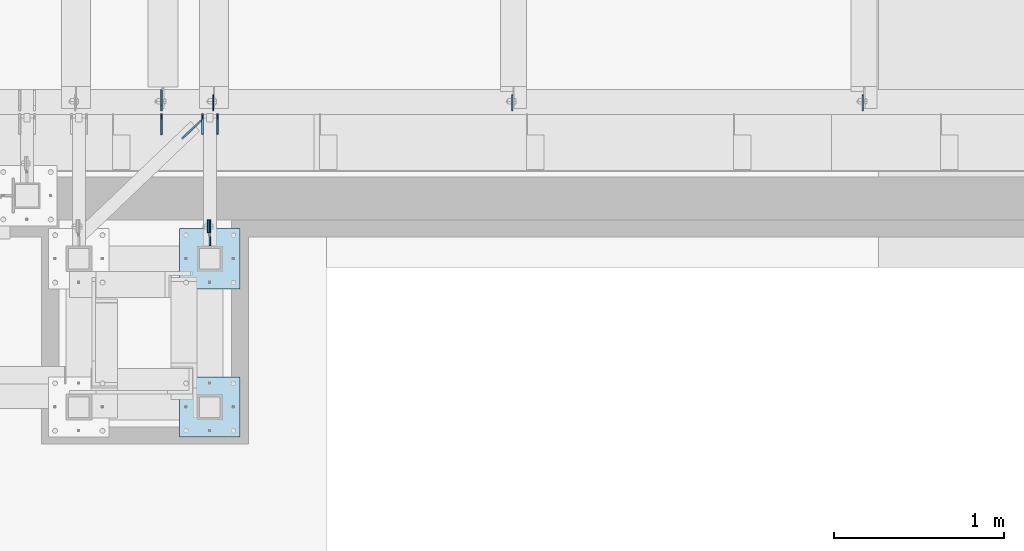
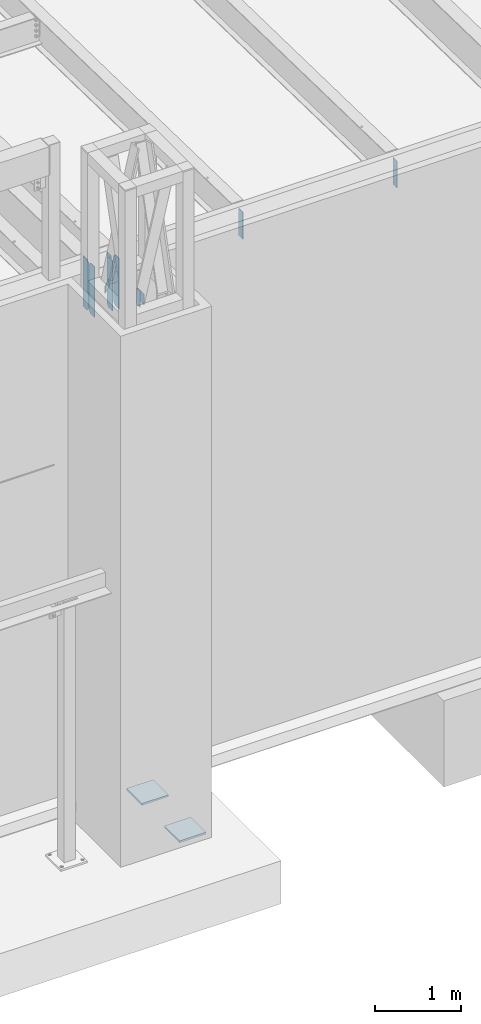
# One storey, part 1484 of 1763: 12 plates, 3 elements without a shape of their own.
"""IFC2X3 building model written with IfcOpenShell, lengths in millimetres."""

from ifc_helpers import new_model, si_unit, frame, origin_with_axes, place, context, subcontext, project, spatial, faceted_brep, material, type_object, element, aggregate, save


model = new_model("IFC2X3")

# Units and contexts
model_context = context("Model", 3, precision=1e-05, world=origin_with_axes())
body_context = subcontext(model_context, "Body", "Model", "MODEL_VIEW")
ifc_project = project(units=[si_unit("LENGTHUNIT", "METRE", prefix="MILLI"), si_unit("AREAUNIT", "SQUARE_METRE"), si_unit("VOLUMEUNIT", "CUBIC_METRE"), si_unit("MASSUNIT", "GRAM", prefix="KILO"), si_unit("TIMEUNIT", "SECOND"), si_unit("PLANEANGLEUNIT", "RADIAN"), si_unit("SOLIDANGLEUNIT", "STERADIAN"), si_unit("THERMODYNAMICTEMPERATUREUNIT", "DEGREE_CELSIUS"), si_unit("LUMINOUSINTENSITYUNIT", "LUMEN")], contexts=[model_context])

# Site, building, storey
site_placement = place(None, origin_with_axes())
site = spatial("IfcSite", under=ifc_project, at=site_placement, CompositionType="ELEMENT")
building_placement = place(site_placement, origin_with_axes())
building = spatial("IfcBuilding", under=site, at=building_placement, Name="Undefined", CompositionType="ELEMENT")
storey_placement = place(building_placement, origin_with_axes())
storey = spatial("IfcBuildingStorey", under=building, at=storey_placement, Name="Undefined", CompositionType="ELEMENT", Elevation=0.0)

# Assembly, plate
assembly_1_placement = place(storey_placement, origin_with_axes())
assembly_1 = element("IfcElementAssembly", 1, at=assembly_1_placement, inside=storey, Name="BEAM", AssemblyPlace="NOTDEFINED", PredefinedType="RIGID_FRAME")
ifc_material = material(Name="STEEL/A36")
plate_type_1 = type_object("IfcPlateType", PredefinedType="NOTDEFINED")
plate_1_placement = place(assembly_1_placement, frame((-40877.5634950282, -14427.1305908063, 11858.625), z_axis=(0.0, 0.0, 1.0), x_axis=(0.0, 1.0, 0.0)))
plate_1 = element("IfcPlate", 2, at=plate_1_placement, type_object=plate_type_1, material=ifc_material, Name="PLATE", context=body_context, shape_type="Brep", body=[
    faceted_brep([(0.0, -4.76249999999982, 0.0), (-2.83762346953154e-10, -4.7624999996915, 228.600006103516), (-2.83762346953154e-10, 4.76250000028813, 228.600006103517), (0.0, 4.76249999999982, 0.0), (76.1999969480166, -4.76249999961874, 228.600006103516), (76.1999969480166, 4.76250000036089, 228.600006103517), (76.1999969482931, -4.76249999991705, 0.0), (76.1999969482931, 4.76250000006257, 1.81898940354586e-12)], [[[0, 1, 2, 3]], [[1, 4, 5, 2]], [[4, 6, 7, 5]], [[6, 0, 3, 7]], [[5, 7, 3, 2]], [[6, 4, 1, 0]]]),
])
aggregate(assembly_1, [plate_1])

# Assembly, plates
assembly_2_placement = place(storey_placement, origin_with_axes())
assembly_2 = element("IfcElementAssembly", 3, at=assembly_2_placement, inside=storey, Name="BEAM", AssemblyPlace="NOTDEFINED", PredefinedType="RIGID_FRAME")
plate_type_2 = type_object("IfcPlateType", PredefinedType="NOTDEFINED")
plate_2_placement = place(assembly_2_placement, frame((-40823.5884956269, -13844.5873186171, 11463.3375), z_axis=(0.0, 0.0, 1.0), x_axis=(0.0, 1.0, 0.0)))
plate_2 = element("IfcPlate", 4, at=plate_2_placement, type_object=plate_type_2, material=ifc_material, Name="PLATE", context=body_context, shape_type="Brep", body=[
    faceted_brep([(0.0, -4.76249999999982, 0.0), (0.0, -4.76249999999709, 714.375), (0.0, 4.76249999999709, 714.375), (0.0, 4.76249999999982, 0.0), (88.9000015258789, -4.76249999999709, 714.375), (88.9000015258789, 4.76249999999709, 714.375), (120.650001525879, -4.76249999999709, 682.625), (120.650001525879, 4.76249999999709, 682.625), (120.650001525879, -4.76249999999709, 31.75), (120.650001525879, 4.76249999999709, 31.75), (88.9000015258789, -4.76249999999709, 0.0), (88.9000015258789, 4.76249999999709, 0.0)], [[[0, 1, 2, 3]], [[1, 4, 5, 2]], [[4, 6, 7, 5]], [[6, 8, 9, 7]], [[8, 10, 11, 9]], [[10, 0, 3, 11]], [[5, 7, 9, 11, 3, 2]], [[10, 8, 6, 4, 1, 0]]]),
])
plate_3_placement = place(assembly_2_placement, frame((-40910.9009956269, -13844.5873186171, 11463.3375), z_axis=(0.0, 0.0, 1.0), x_axis=(0.0, 1.0, 0.0)))
plate_3 = element("IfcPlate", 5, at=plate_3_placement, type_object=plate_type_2, material=ifc_material, Name="PLATE", context=body_context, shape_type="Brep", body=[
    faceted_brep([(0.0, -4.76249999999982, 0.0), (0.0, -4.76249999999709, 714.375), (0.0, 4.76249999999709, 714.375), (0.0, 4.76249999999982, 0.0), (88.9000015258789, -4.76249999999709, 714.375), (88.9000015258789, 4.76249999999709, 714.375), (120.650001525879, -4.76249999999709, 682.625), (120.650001525879, 4.76249999999709, 682.625), (120.650001525879, -4.76249999999709, 31.75), (120.650001525879, 4.76249999999709, 31.75), (88.9000015258789, -4.76249999999709, 0.0), (88.9000015258789, 4.76249999999709, 0.0)], [[[0, 1, 2, 3]], [[1, 4, 5, 2]], [[4, 6, 7, 5]], [[6, 8, 9, 7]], [[8, 10, 11, 9]], [[10, 0, 3, 11]], [[5, 7, 9, 11, 3, 2]], [[10, 8, 6, 4, 1, 0]]]),
])

assembly_3_placement = place(storey_placement, origin_with_axes())
assembly_3 = element("IfcElementAssembly", 6, at=assembly_3_placement, inside=storey, Name="FRAME", AssemblyPlace="NOTDEFINED", PredefinedType="RIGID_FRAME")
plate_type_3 = type_object("IfcPlateType", PredefinedType="NOTDEFINED")
plate_4_placement = place(assembly_3_placement, frame((-40868.0384965282, -14350.9305938105, 12087.2250061035), z_axis=(0.0, 0.0, -1.0), x_axis=(0.0, -1.0, 0.0)))
plate_4 = element("IfcPlate", 7, at=plate_4_placement, type_object=plate_type_3, material=ifc_material, Name="PLATE", context=body_context, shape_type="Brep", body=[
    faceted_brep([(0.0, -4.76249999999982, 0.0), (-3.05175672110636e-06, -4.7625000002663, 152.399993896484), (-3.05175490211695e-06, 4.76249999972788, 152.399993896484), (0.0, 4.76249999999982, 0.0), (152.400009155272, -4.76249999975698, 152.399993896484), (152.400009155273, 4.76250000024447, 152.399993896484), (152.400009155272, -4.76249999948777, 5.45696821063757e-12), (152.400009155273, 4.76250000051368, 3.63797880709171e-12)], [[[0, 1, 2, 3]], [[1, 4, 5, 2]], [[4, 6, 7, 5]], [[6, 0, 3, 7]], [[5, 7, 3, 2]], [[6, 4, 1, 0]]]),
])
plate_type_4 = type_object("IfcPlateType", PredefinedType="NOTDEFINED")
plate_5_placement = place(assembly_3_placement, frame((-41045.8383006056, -14401.7306029674, 5079.99999999999), z_axis=(1.0, 0.0, 0.0), x_axis=(0.0, -1.0, 0.0)))
plate_5 = element("IfcPlate", 8, at=plate_5_placement, type_object=plate_type_4, material=ifc_material, Name="PLATE", context=body_context, shape_type="Brep", body=[
    faceted_brep([(0.0, -12.6999999999971, -1.81898940354586e-12), (0.0, -12.6999999999998, 355.600006103516), (0.0, 12.6999999999998, 355.600006103516), (0.0, 12.6999999999971, -1.81898940354586e-12), (355.600006103516, -12.6999999999998, 355.600006103516), (355.600006103516, 12.6999999999998, 355.600006103516), (355.600006103516, -12.6999999999998, 0.0), (355.600006103516, 12.6999999999998, 0.0)], [[[0, 1, 2, 3]], [[1, 4, 5, 2]], [[4, 6, 7, 5]], [[6, 0, 3, 7]], [[5, 7, 3, 2]], [[6, 4, 1, 0]]]),
])
plate_6_placement = place(assembly_3_placement, frame((-41045.8383006056, -15274.8556029674, 5079.99999999999), z_axis=(1.0, 0.0, 0.0), x_axis=(0.0, -1.0, 0.0)))
plate_6 = element("IfcPlate", 9, at=plate_6_placement, type_object=plate_type_4, material=ifc_material, Name="PLATE", context=body_context, shape_type="Brep", body=[
    faceted_brep([(0.0, -12.6999999999971, -1.81898940354586e-12), (0.0, -12.6999999999998, 355.600006103516), (0.0, 12.6999999999998, 355.600006103516), (0.0, 12.6999999999971, -1.81898940354586e-12), (355.600006103516, -12.6999999999998, 355.600006103516), (355.600006103516, 12.6999999999998, 355.600006103516), (355.600006103516, -12.6999999999998, 0.0), (355.600006103516, 12.6999999999998, 0.0)], [[[0, 1, 2, 3]], [[1, 4, 5, 2]], [[4, 6, 7, 5]], [[6, 0, 3, 7]], [[5, 7, 3, 2]], [[6, 4, 1, 0]]]),
])
aggregate(assembly_3, [plate_4, plate_5, plate_6])

# Plate
plate_type_5 = type_object("IfcPlateType", PredefinedType="NOTDEFINED")
plate_7_placement = place(assembly_2_placement, frame((-41028.1613806478, -13868.8601204185, 11769.725), z_axis=(0.0, 0.0, 1.0), x_axis=(0.723320631729244, 0.690512319741514, 0.0)))
plate_7 = element("IfcPlate", 10, at=plate_7_placement, type_object=plate_type_5, material=ifc_material, Name="PLATE", context=body_context, shape_type="Brep", body=[
    faceted_brep([(0.0, -4.76249999999982, 0.0), (1.45519152283669e-11, -4.76250000000448, 101.60001373291), (0.0, 4.76250000000243, 101.60001373291), (0.0, 4.76249999999982, 0.0), (150.983306885064, -4.76250000033906, 101.60001373291), (150.9833068851, 4.76249999961874, 101.60001373291), (150.983306885064, -4.76250000033906, 0.0), (150.9833068851, 4.76249999961874, 0.0)], [[[0, 1, 2, 3]], [[1, 4, 5, 2]], [[4, 6, 7, 5]], [[6, 0, 3, 7]], [[5, 7, 3, 2]], [[6, 4, 1, 0]]]),
])

plate_type_6 = type_object("IfcPlateType", PredefinedType="NOTDEFINED")
plate_8_placement = place(assembly_2_placement, frame((-40848.9884959181, -13708.0623186171, 12141.4722391463), z_axis=(0.0, 1.0, 0.0), x_axis=(0.0, 0.0, -1.0)))
plate_8 = element("IfcPlate", 11, at=plate_8_placement, type_object=plate_type_6, material=ifc_material, Name="PLATE", context=body_context, shape_type="Brep", body=[
    faceted_brep([(1.81898940354586e-12, -3.17500000000291, 0.0), (0.0, -3.17499999999927, 93.6624984741211), (0.0, 3.17499999999927, 93.6624984741211), (-1.81898940354586e-12, 3.17499999997381, 0.0), (228.600006103516, -3.17499999999927, 93.6624984741211), (228.600006103516, 3.17499999999927, 93.6624984741211), (228.600006103516, -3.17500000001019, -7.27595761418343e-12), (228.600006103516, 3.17499999999563, -7.27595761418343e-12)], [[[0, 1, 2, 3]], [[1, 4, 5, 2]], [[4, 6, 7, 5]], [[6, 0, 3, 7]], [[5, 7, 3, 2]], [[6, 4, 1, 0]]]),
])

plate_type_7 = type_object("IfcPlateType", PredefinedType="NOTDEFINED")
plate_9_placement = place(assembly_2_placement, frame((-41153.3342021858, -13723.9373186171, 11461.75), z_axis=(0.0, 0.0, 1.0), x_axis=(0.0, -1.0, 0.0)))
plate_9 = element("IfcPlate", 12, at=plate_9_placement, type_object=plate_type_7, material=ifc_material, Name="PLATE", context=body_context, shape_type="Brep", body=[
    faceted_brep([(0.0, -4.76250000000073, 31.75), (0.0, -4.76250000000073, 685.799987792969), (0.0, 4.76250000000073, 685.799987792969), (0.0, 4.76250000000073, 31.75), (31.75, -4.76250000000073, 717.549987792969), (31.75, 4.76250000000073, 717.549987792969), (125.412498474121, -4.76249999999709, 717.549987792969), (125.412498474121, 4.76249999999709, 717.549987792969), (125.412498474121, -4.76249999999709, 0.0), (125.412498474121, 4.76249999999709, 0.0), (31.75, -4.76250000000073, 0.0), (31.75, 4.76250000000073, 0.0)], [[[0, 1, 2, 3]], [[1, 4, 5, 2]], [[4, 6, 7, 5]], [[6, 8, 9, 7]], [[8, 10, 11, 9]], [[10, 0, 3, 11]], [[5, 7, 9, 11, 3, 2]], [[10, 8, 6, 4, 1, 0]]]),
])

plate_10_placement = place(assembly_2_placement, frame((-41153.3342021858, -13708.0623186171, 11463.3375), z_axis=(0.0, 0.0, 1.0), x_axis=(0.0, 1.0, 0.0)))
plate_10 = element("IfcPlate", 13, at=plate_10_placement, type_object=plate_type_7, material=ifc_material, Name="PLATE", context=body_context, shape_type="Brep", body=[
    faceted_brep([(0.0, -4.76250000000073, 31.75), (0.0, -4.76249999999709, 684.21248626709), (0.0, 4.76249999999709, 684.21248626709), (0.0, 4.76250000000073, 31.75), (31.75, -4.76249999999709, 715.962524414062), (31.75, 4.76249999999709, 715.962524414062), (125.412498474121, -4.76249999999709, 715.962524414062), (125.412498474121, 4.76249999999709, 715.962524414062), (125.412498474121, -4.76249999999709, 0.0), (125.412498474121, 4.76249999999709, 0.0), (31.75, -4.76250000000073, 0.0), (31.75, 4.76250000000073, 0.0)], [[[0, 1, 2, 3]], [[1, 4, 5, 2]], [[4, 6, 7, 5]], [[6, 8, 9, 7]], [[8, 10, 11, 9]], [[10, 0, 3, 11]], [[5, 7, 9, 11, 3, 2]], [[10, 8, 6, 4, 1, 0]]]),
])

plate_type_8 = type_object("IfcPlateType", PredefinedType="NOTDEFINED")
plate_11_placement = place(assembly_2_placement, frame((-37022.4321665555, -13708.0623186171, 12141.4381181098), z_axis=(0.0, 1.0, 0.0), x_axis=(0.0, 0.0, -1.0)))
plate_11 = element("IfcPlate", 14, at=plate_11_placement, type_object=plate_type_8, material=ifc_material, Name="PLATE", context=body_context, shape_type="Brep", body=[
    faceted_brep([(0.0, -3.96900000000096, 0.0), (0.0, -3.96899999999732, 93.6624984741211), (0.0, 3.96899999999732, 93.6624984741211), (0.0, 3.96900000000096, 0.0), (381.0, -3.96899999999732, 93.6624984741211), (381.0, 3.96899999999732, 93.6624984741211), (381.0, -3.96900000001915, 3.34694050252438e-10), (381.0, 3.9690000000046, 3.20142135024071e-10)], [[[0, 1, 2, 3]], [[1, 4, 5, 2]], [[4, 6, 7, 5]], [[6, 0, 3, 7]], [[5, 7, 3, 2]], [[6, 4, 1, 0]]]),
])

plate_12_placement = place(assembly_2_placement, frame((-39087.0893094126, -13708.0623186171, 12141.4381181091), z_axis=(0.0, 1.0, 0.0), x_axis=(0.0, 0.0, -1.0)))
plate_12 = element("IfcPlate", 15, at=plate_12_placement, type_object=plate_type_8, material=ifc_material, Name="PLATE", context=body_context, shape_type="Brep", body=[
    faceted_brep([(0.0, -3.96900000000096, 0.0), (0.0, -3.96899999999732, 93.6624984741211), (0.0, 3.96899999999732, 93.6624984741211), (0.0, 3.96900000000096, 0.0), (381.0, -3.96899999999732, 93.6624984741211), (381.0, 3.96899999999732, 93.6624984741211), (381.0, -3.96900000001915, 3.34694050252438e-10), (381.0, 3.9690000000046, 3.20142135024071e-10)], [[[0, 1, 2, 3]], [[1, 4, 5, 2]], [[4, 6, 7, 5]], [[6, 0, 3, 7]], [[5, 7, 3, 2]], [[6, 4, 1, 0]]]),
])

aggregate(assembly_2, [plate_7, plate_2, plate_3, plate_11, plate_12, plate_9, plate_10, plate_8])

save(model, "model.ifc")
